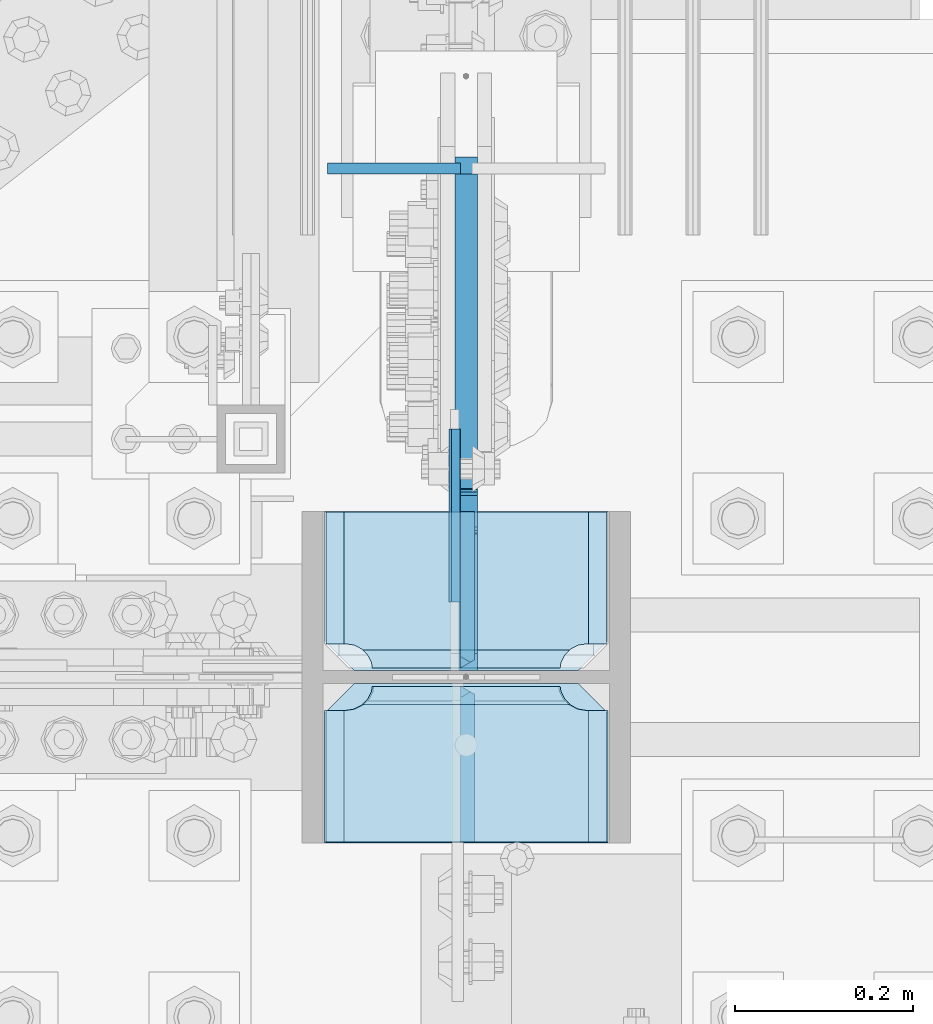
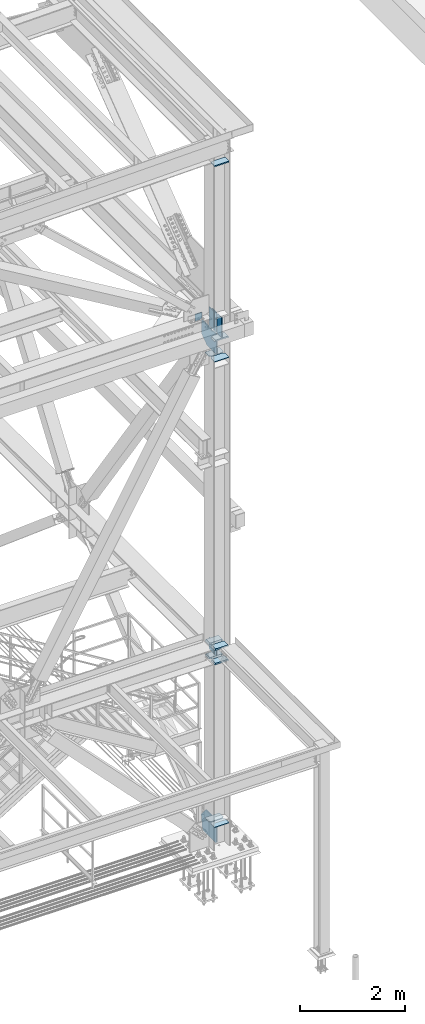
# One storey, part 3566 of 3843: 18 plates, 2 elements without a shape of their own.
"""IFC2X3 building model written with IfcOpenShell, lengths in millimetres."""

from ifc_helpers import new_model, si_unit, frame, origin_with_axes, place, context, subcontext, project, spatial, faceted_brep, material, type_object, element, aggregate, save


model = new_model("IFC2X3")

# Units and contexts
model_context = context("Model", 3, precision=1e-05, world=origin_with_axes())
body_context = subcontext(model_context, "Body", "Model", "MODEL_VIEW")
ifc_project = project(units=[si_unit("LENGTHUNIT", "METRE", prefix="MILLI"), si_unit("AREAUNIT", "SQUARE_METRE"), si_unit("VOLUMEUNIT", "CUBIC_METRE"), si_unit("MASSUNIT", "GRAM", prefix="KILO"), si_unit("TIMEUNIT", "SECOND"), si_unit("PLANEANGLEUNIT", "RADIAN"), si_unit("SOLIDANGLEUNIT", "STERADIAN"), si_unit("THERMODYNAMICTEMPERATUREUNIT", "DEGREE_CELSIUS"), si_unit("LUMINOUSINTENSITYUNIT", "LUMEN")], contexts=[model_context])

# Site, building, storey
site_placement = place(None, origin_with_axes())
site = spatial("IfcSite", under=ifc_project, at=site_placement, CompositionType="ELEMENT")
building_placement = place(site_placement, origin_with_axes())
building = spatial("IfcBuilding", under=site, at=building_placement, Name="Undefined", CompositionType="ELEMENT")
storey_placement = place(building_placement, origin_with_axes())
storey = spatial("IfcBuildingStorey", under=building, at=storey_placement, Name="Undefined", CompositionType="ELEMENT", Elevation=0.0)

# Assembly, plate
assembly_1_placement = place(storey_placement, origin_with_axes())
assembly_1 = element("IfcElementAssembly", 1, at=assembly_1_placement, inside=storey, Name="BEAM", AssemblyPlace="NOTDEFINED", PredefinedType="RIGID_FRAME")
ifc_material = material(Name="STEEL/A572-50")
plate_type_1 = type_object("IfcPlateType", PredefinedType="NOTDEFINED")
plate_1_placement = place(assembly_1_placement, frame((85493.225, 15568.6522904443, 42110.025), z_axis=(0.0, 0.0, -1.0), x_axis=(1.0, 0.0, 0.0)))
plate_1 = element("IfcPlate", 2, at=plate_1_placement, type_object=plate_type_1, material=ifc_material, Name="PLATE", context=body_context, shape_type="Brep", body=[
    faceted_brep([(0.0, -6.3499999046162, 0.0), (0.0, -6.34999999999854, 163.512499999997), (0.0, 6.34999999999854, 163.512499999997), (7.27595761418343e-12, 6.3499999046162, 0.0), (117.474999999991, -6.34999999999854, 163.512499999997), (117.474999999991, 6.34999999999854, 163.512499999997), (149.224999999991, -6.34999999999854, 131.762499999997), (149.224999999991, 6.34999999999854, 131.762499999997), (149.224999999991, -6.35000000000582, 0.0), (149.224999999991, 6.35000000000582, 0.0)], [[[0, 1, 2, 3]], [[1, 4, 5, 2]], [[4, 6, 7, 5]], [[6, 8, 9, 7]], [[8, 0, 3, 9]], [[5, 7, 9, 3, 2]], [[8, 6, 4, 1, 0]]]),
])
aggregate(assembly_1, [plate_1])

# Assembly, plates
assembly_2_placement = place(storey_placement, origin_with_axes())
assembly_2 = element("IfcElementAssembly", 3, at=assembly_2_placement, inside=storey, Name="COLUMN", AssemblyPlace="NOTDEFINED", PredefinedType="RIGID_FRAME")
plate_type_2 = type_object("IfcPlateType", PredefinedType="NOTDEFINED")
plate_2_placement = place(assembly_2_placement, frame((85807.55, 15005.84375, 41459.7674550798), z_axis=(0.0, 1.0, 0.0), x_axis=(-1.0, 0.0, 0.0)))
plate_2 = element("IfcPlate", 4, at=plate_2_placement, type_object=plate_type_2, material=ifc_material, Name="CB_COL", context=body_context, shape_type="Brep", body=[
    faceted_brep([(0.0, -6.34999999999854, 33.3375015258789), (0.0, -6.34999999999854, 178.59375), (0.0, 6.34999999999854, 178.59375), (0.0, 6.34999999999854, 33.3375015258789), (317.499999999985, -6.34999999999854, 178.59375), (317.499999999985, 6.34999999999854, 178.59375), (317.499999999985, -6.34999999999854, 33.3375015258789), (317.499999999985, 6.34999999999854, 33.3375015258789), (284.162498474107, -6.34999999999854, 0.0), (284.162498474107, 6.34999999999854, 0.0), (33.3375015258789, -6.34999999999854, 0.0), (33.3375015258789, 6.34999999999854, 0.0)], [[[0, 1, 2, 3]], [[1, 4, 5, 2]], [[4, 6, 7, 5]], [[6, 8, 9, 7]], [[8, 10, 11, 9]], [[10, 0, 3, 11]], [[5, 7, 9, 11, 3, 2]], [[10, 8, 6, 4, 1, 0]]]),
])
plate_3_placement = place(assembly_2_placement, frame((85807.55, 14991.55625, 41459.7674550798), z_axis=(0.0, -1.0, 0.0), x_axis=(-1.0, 0.0, 0.0)))
plate_3 = element("IfcPlate", 5, at=plate_3_placement, type_object=plate_type_2, material=ifc_material, Name="CB_COL", context=body_context, shape_type="Brep", body=[
    faceted_brep([(0.0, -6.34999999999854, 33.3375015258789), (0.0, -6.34999999999854, 178.59375), (0.0, 6.34999999999854, 178.59375), (0.0, 6.34999999999854, 33.3375015258789), (317.499999999985, -6.34999999999854, 178.59375), (317.499999999985, 6.34999999999854, 178.59375), (317.499999999985, -6.34999999999854, 33.3375015258789), (317.499999999985, 6.34999999999854, 33.3375015258789), (284.162498474107, -6.34999999999854, 0.0), (284.162498474107, 6.34999999999854, 0.0), (33.3375015258789, -6.34999999999854, 0.0), (33.3375015258789, 6.34999999999854, 0.0)], [[[0, 1, 2, 3]], [[1, 4, 5, 2]], [[4, 6, 7, 5]], [[6, 8, 9, 7]], [[8, 10, 11, 9]], [[10, 0, 3, 11]], [[5, 7, 9, 11, 3, 2]], [[10, 8, 6, 4, 1, 0]]]),
])
plate_4_placement = place(assembly_2_placement, frame((85807.55, 15005.84375, 30683.648293866), z_axis=(0.0, 1.0, 0.0), x_axis=(-1.0, 0.0, 0.0)))
plate_4 = element("IfcPlate", 6, at=plate_4_placement, type_object=plate_type_2, material=ifc_material, Name="CB_COL", context=body_context, shape_type="Brep", body=[
    faceted_brep([(0.0, -6.34999999999854, 33.3375015258789), (0.0, -6.34999999999854, 178.59375), (0.0, 6.34999999999854, 178.59375), (0.0, 6.34999999999854, 33.3375015258789), (317.499999999985, -6.34999999999854, 178.59375), (317.499999999985, 6.34999999999854, 178.59375), (317.499999999985, -6.34999999999854, 33.3375015258789), (317.499999999985, 6.34999999999854, 33.3375015258789), (284.162498474107, -6.34999999999854, 0.0), (284.162498474107, 6.34999999999854, 0.0), (33.3375015258789, -6.34999999999854, 0.0), (33.3375015258789, 6.34999999999854, 0.0)], [[[0, 1, 2, 3]], [[1, 4, 5, 2]], [[4, 6, 7, 5]], [[6, 8, 9, 7]], [[8, 10, 11, 9]], [[10, 0, 3, 11]], [[5, 7, 9, 11, 3, 2]], [[10, 8, 6, 4, 1, 0]]]),
])
plate_5_placement = place(assembly_2_placement, frame((85807.55, 14991.55625, 30683.648293866), z_axis=(0.0, -1.0, 0.0), x_axis=(-1.0, 0.0, 0.0)))
plate_5 = element("IfcPlate", 7, at=plate_5_placement, type_object=plate_type_2, material=ifc_material, Name="CB_COL", context=body_context, shape_type="Brep", body=[
    faceted_brep([(0.0, -6.34999999999854, 33.3375015258789), (0.0, -6.34999999999854, 178.59375), (0.0, 6.34999999999854, 178.59375), (0.0, 6.34999999999854, 33.3375015258789), (317.499999999985, -6.34999999999854, 178.59375), (317.499999999985, 6.34999999999854, 178.59375), (317.499999999985, -6.34999999999854, 33.3375015258789), (317.499999999985, 6.34999999999854, 33.3375015258789), (284.162498474107, -6.34999999999854, 0.0), (284.162498474107, 6.34999999999854, 0.0), (33.3375015258789, -6.34999999999854, 0.0), (33.3375015258789, 6.34999999999854, 0.0)], [[[0, 1, 2, 3]], [[1, 4, 5, 2]], [[4, 6, 7, 5]], [[6, 8, 9, 7]], [[8, 10, 11, 9]], [[10, 0, 3, 11]], [[5, 7, 9, 11, 3, 2]], [[10, 8, 6, 4, 1, 0]]]),
])
plate_type_3 = type_object("IfcPlateType", PredefinedType="NOTDEFINED")
plate_6_placement = place(assembly_2_placement, frame((85809.1375, 14991.55625, 41941.75), z_axis=(-1.0, 0.0, 0.0), x_axis=(0.0, -1.0, 0.0)))
plate_6 = element("IfcPlate", 8, at=plate_6_placement, type_object=plate_type_3, material=ifc_material, Name="PLATE", context=body_context, shape_type="Brep", body=[
    faceted_brep([(17.7290728964945, 9.33296078367857, 270.873024980028), (21.5061209990872, 15.875, 274.650073082623), (21.5061209990872, 15.875, 46.0249269173801), (17.7290728964945, 9.33296078367857, 49.8019750199746), (9.32072521071495, -5.23072461579432, 54.0862421540805), (3.17524995231724, -15.875, 55.0595898134052), (3.17524995231724, -15.875, 265.615410186598), (9.32072521071677, -5.23072461578704, 266.588757845922), (177.799999999999, 15.875, 21.5053709990898), (177.799999999999, -15.875, 3.17449995232164), (30.1625003814697, -15.875, 3.17449995232164), (30.1625003814697, 15.875, 21.5053709990898), (30.1625003814697, 15.875, 299.168629000924), (30.1625003814697, -15.875, 317.499500047692), (177.799999999999, -15.875, 317.499500047692), (177.799999999999, 15.875, 299.168629000924), (9.32072521071677, -15.875, 266.588757845922), (17.7290728964945, -15.875, 270.873024980028), (24.4019754014498, -15.875, 277.545927484985), (24.4019754014498, 15.875, 277.545927484985), (28.6862425355521, -15.875, 285.954275170763), (28.6862425355521, 15.875, 285.954275170763), (30.1625003814697, -15.875, 295.275000381473), (30.1625003814697, 15.875, 295.275000381473), (30.1625003814697, -15.875, 25.3999996185303), (30.1625003814697, 15.875, 25.3999996185303), (28.6862425355521, -15.875, 34.7207248292398), (28.6862425355521, 15.875, 34.7207248292398), (24.4019754014498, -15.875, 43.1290725150175), (24.4019754014498, 15.875, 43.1290725150175), (17.7290728964945, -15.875, 49.8019750199746), (9.32072521071495, -15.875, 54.0862421540805)], [[[0, 1, 2, 3, 4, 5, 6, 7]], [[8, 9, 10, 11]], [[12, 13, 14, 15]], [[16, 7, 6]], [[16, 17, 0, 7]], [[17, 18, 19, 1, 0]], [[18, 20, 21, 19]], [[20, 22, 23, 21]], [[23, 22, 13, 12]], [[9, 8, 15, 14]], [[24, 25, 11, 10]], [[24, 26, 27, 25]], [[26, 28, 29, 27]], [[29, 28, 30, 3, 2]], [[30, 31, 4, 3]], [[31, 5, 4]], [[19, 21, 23, 12, 15, 8, 11, 25, 27, 29, 2, 1]], [[31, 30, 28, 26, 24, 10, 9, 14, 13, 22, 20, 18, 17, 16, 6, 5]]]),
])
plate_type_4 = type_object("IfcPlateType", PredefinedType="NOTDEFINED")
plate_7_placement = place(assembly_2_placement, frame((85636.89375, 15276.512498474, 34761.4875), z_axis=(0.0, 0.0, -1.0), x_axis=(0.0, -1.0, 0.0)))
plate_7 = element("IfcPlate", 9, at=plate_7_placement, type_object=plate_type_4, material=ifc_material, Name="PLATE", context=body_context, shape_type="Brep", body=[
    faceted_brep([(0.0, -4.76249999999709, 0.0), (1.45519152283669e-11, -4.76249999999709, 269.874990844721), (1.45519152283669e-11, 4.76249999999709, 269.874990844721), (0.0, 4.76249999999709, 0.0), (193.675000000003, -4.76249999999709, 269.874990844721), (193.675000000003, 4.76249999999709, 269.874990844721), (193.674999999996, -4.76249999999709, 0.0), (193.674999999996, 4.76249999999709, 0.0)], [[[0, 1, 2, 3]], [[1, 4, 5, 2]], [[4, 6, 7, 5]], [[6, 0, 3, 7]], [[5, 7, 3, 2]], [[6, 4, 1, 0]]]),
])
plate_type_5 = type_object("IfcPlateType", PredefinedType="NOTDEFINED")
plate_8_placement = place(assembly_2_placement, frame((85649.59375, 15005.8442500019, 34496.375), z_axis=(0.0, 0.707106781186548, 0.707106781186548), x_axis=(5.70000238222118e-08, 0.707106781186546, -0.707106781186546)))
plate_8 = element("IfcPlate", 10, at=plate_8_placement, type_object=plate_type_5, material=ifc_material, Name="PLATE", context=body_context, shape_type="Brep", body=[
    faceted_brep([(-184.095250465922, 7.9375, 188.585378458942), (4.49012799373304, 7.9375, 0.0), (13.4703841824085, -3.06102271161217, -3.63797880709171e-12), (13.4703841830633, -7.9375, 3.98162703275011), (-180.113623446356, -7.9375, 197.565634661863), (-184.095250465834, -3.06102272757562, 197.565634661427), (-62.5551309118237, -7.93749999991269, 315.124127196395), (-69.036072523144, 7.9375, 321.605068804565), (-184.095250465754, 7.9375, 206.545890861948), (22.4506403697887, 7.9375, -1.81898940354586e-11), (137.509818323706, 7.93750000094587, 115.059177953997), (131.028876714001, -7.9375, 121.540119563797), (128.529562034935, 7.9375, 124.039434242863), (128.529562034935, -7.9375, 124.039434242863), (-60.0558162178277, 7.9375, 312.624812503636), (-60.0558162178277, -7.9375, 312.624812503636)], [[[0, 1, 2, 3, 4, 5]], [[6, 7, 8, 5, 4]], [[9, 2, 1]], [[9, 10, 11, 3, 2]], [[12, 13, 11, 10]], [[14, 15, 13, 12]], [[11, 13, 15, 6, 4, 3]], [[8, 0, 5]], [[14, 12, 10, 9, 1, 0, 8, 7]], [[15, 14, 7, 6]]]),
])
plate_9_placement = place(assembly_2_placement, frame((85650.3875, 15005.8437500036, 41976.6750000008), z_axis=(0.0, 0.707106781186548, 0.707106781186548), x_axis=(5.70000238222118e-08, 0.707106781186546, -0.707106781186546)))
plate_9 = element("IfcPlate", 11, at=plate_9_placement, type_object=plate_type_5, material=ifc_material, Name="PLATE", context=body_context, shape_type="Brep", body=[
    faceted_brep([(-312.063900187669, 7.9375, 316.55402818077), (4.49012799373304, 7.9375, 0.0), (13.4703841824085, -3.06102271161217, -3.63797880709171e-12), (13.4703841830633, -7.9375, 3.98162703275011), (-308.082273151626, -7.9375, 325.53428436687), (-312.06390018768, -3.06102270777046, 325.534284366877), (-190.523427063413, -7.9375, 443.093130455098), (-197.004368674482, 7.9375, 449.574072066178), (-312.063900187676, 7.9375, 334.514540552969), (22.4506403697887, 7.9375, -1.81898940354586e-11), (137.510171880771, 7.93750000091677, 115.059531510957), (131.029230271015, -7.9375, 121.540473120702), (62.3005266916225, 7.9375, 190.269176711488), (62.3005266916225, -7.9375, 190.269176711488), (-171.186132170253, 7.9375, 423.755835579228), (-171.186132170253, -7.9375, 423.755835579228)], [[[0, 1, 2, 3, 4, 5]], [[6, 7, 8, 5, 4]], [[9, 2, 1]], [[9, 10, 11, 3, 2]], [[12, 13, 11, 10]], [[14, 15, 13, 12]], [[11, 13, 15, 6, 4, 3]], [[8, 0, 5]], [[14, 12, 10, 9, 1, 0, 8, 7]], [[15, 14, 7, 6]]]),
])
plate_10_placement = place(assembly_2_placement, frame((85650.3875, 14991.55625, 41976.6750000001), z_axis=(0.0, -0.707106781186682, 0.707106781186413), x_axis=(0.0, -0.707106781186548, -0.707106781186548)))
plate_10 = element("IfcPlate", 12, at=plate_10_placement, type_object=plate_type_5, material=ifc_material, Name="PLATE", context=body_context, shape_type="Brep", body=[
    faceted_brep([(4.49012799309094, -7.9375, 7.27595761418343e-12), (-312.063900203553, -7.9375, 316.554028203769), (-312.063900203248, 3.06102270915289, 325.534284391004), (-308.082273168307, 7.9375, 325.534284391018), (13.470384184775, 7.9375, 3.98162703046546), (13.4703841731916, 3.06102272879798, -7.27595761418343e-12), (-312.06390018767, -7.9375, 334.514540549832), (-197.565634686391, -7.9375, 449.0128060934), (-191.084693076795, 7.93749999991269, 442.531864483506), (22.4506403026729, -7.93750001103617, 0.0), (130.467964270647, 7.9375, 120.979207121221), (136.948905880243, -7.93750000094587, 114.498265511327)], [[[0, 1, 2, 3, 4, 5]], [[6, 7, 8, 3, 2]], [[9, 0, 5]], [[10, 11, 9, 5, 4]], [[11, 10, 8, 7]], [[1, 0, 9, 11, 7, 6]], [[6, 2, 1]], [[8, 10, 4, 3]]]),
])
plate_type_6 = type_object("IfcPlateType", PredefinedType="NOTDEFINED")
plate_11_placement = place(assembly_2_placement, frame((85636.0999999999, 15276.5124995919, 42413.2375), z_axis=(0.0, 0.0, -1.0), x_axis=(0.0, -1.0, 0.0)))
plate_11 = element("IfcPlate", 13, at=plate_11_placement, type_object=plate_type_6, material=ifc_material, Name="PLATE", context=body_context, shape_type="Brep", body=[
    faceted_brep([(0.0, -6.3499999046162, 0.0), (0.0, -6.35000000000582, 431.800000000003), (0.0, 6.35000000000582, 431.800000000003), (7.27595761418343e-12, 6.3499999046162, 0.0), (193.674999999996, -6.35000000000582, 431.800000000003), (193.674999999996, 6.35000000000582, 431.800000000003), (193.674999999996, -6.35000000000582, 0.0), (193.674999999996, 6.35000000000582, 0.0)], [[[0, 1, 2, 3]], [[1, 4, 5, 2]], [[4, 6, 7, 5]], [[6, 0, 3, 7]], [[5, 7, 3, 2]], [[6, 4, 1, 0]]]),
])
plate_type_7 = type_object("IfcPlateType", PredefinedType="NOTDEFINED")
plate_12_placement = place(assembly_2_placement, frame((85807.55, 14991.55625, 45988.2875), z_axis=(-1.0, 0.0, 0.0), x_axis=(0.0, -1.0, 0.0)))
plate_12 = element("IfcPlate", 14, at=plate_12_placement, type_object=plate_type_7, material=ifc_material, Name="PLATE", context=body_context, shape_type="Brep", body=[
    faceted_brep([(17.7290728964945, 10.9204600207377, 267.698024980025), (19.6730343348936, 14.2874999999985, 269.641986418414), (19.6730343348972, 14.2874999999985, 47.8580135815719), (17.7290728964945, 10.9204600207304, 49.8019750199746), (9.32072521071677, -3.6432253787425, 54.0862421540805), (3.17524995232088, -14.2874999999985, 55.0595898134052), (3.17524995231361, -14.2874999999985, 262.440410186595), (9.32072521071495, -3.64322537872067, 263.413757845919), (9.32072521071677, -14.2874999999985, 263.413757845919), (17.7290728964945, -14.2874999999985, 267.698024980025), (24.4019754014516, -14.2874999999985, 274.370927484983), (24.4019754014516, 14.2874999999985, 274.370927484983), (28.6862425355539, -14.2874999999985, 282.77927517076), (28.6862425355539, 14.2874999999985, 282.77927517076), (30.1625003814697, -14.2874999999985, 292.10000038147), (30.1625003814697, 14.2874999999985, 292.10000038147), (30.1625003814697, -14.2874999999985, 317.5), (30.1625003814697, 14.2874999999985, 317.5), (177.800003051758, -14.2874999999985, 317.5), (177.800003051758, 14.2874999999985, 317.5), (177.800003051758, -14.2874999999985, 0.0), (177.800003051758, 14.2874999999985, 0.0), (30.1625003814697, -14.2874999999985, 0.0), (30.1625003814697, 14.2874999999985, 0.0), (30.1625003814697, -14.2874999999985, 25.3999996185303), (30.1625003814697, 14.2874999999985, 25.3999996185303), (28.6862425355503, -14.2874999999985, 34.7207248292398), (28.6862425355503, 14.2874999999985, 34.7207248292398), (24.401975401448, -14.2874999999985, 43.1290725150175), (24.401975401448, 14.2874999999985, 43.1290725150175), (17.7290728964945, -14.2874999999985, 49.8019750199746), (9.32072521071677, -14.2874999999985, 54.0862421540805)], [[[0, 1, 2, 3, 4, 5, 6, 7]], [[8, 7, 6]], [[8, 9, 0, 7]], [[9, 10, 11, 1, 0]], [[10, 12, 13, 11]], [[12, 14, 15, 13]], [[14, 16, 17, 15]], [[16, 18, 19, 17]], [[18, 20, 21, 19]], [[20, 22, 23, 21]], [[22, 24, 25, 23]], [[24, 26, 27, 25]], [[26, 28, 29, 27]], [[29, 28, 30, 3, 2]], [[30, 31, 4, 3]], [[31, 5, 4]], [[11, 13, 15, 17, 19, 21, 23, 25, 27, 29, 2, 1]], [[31, 30, 28, 26, 24, 22, 20, 18, 16, 14, 12, 10, 9, 8, 6, 5]]]),
])
plate_type_8 = type_object("IfcPlateType", PredefinedType="NOTDEFINED")
plate_13_placement = place(assembly_2_placement, frame((85809.1375, 14991.55625, 34459.8625), z_axis=(-1.0, 0.0, 0.0), x_axis=(0.0, -1.0, 0.0)))
plate_13 = element("IfcPlate", 15, at=plate_13_placement, type_object=plate_type_8, material=ifc_material, Name="PLATE", context=body_context, shape_type="Brep", body=[
    faceted_brep([(17.7290728964945, 7.7454615466122, 270.873024980028), (23.3392076632808, 17.4625000000015, 276.483159746815), (23.3392076632808, 17.4625000000015, 44.1918402531883), (17.7290728964945, 7.7454615466122, 49.8019750199746), (9.32072521071495, -6.81822385286068, 54.0862421540805), (3.17524995231724, -17.4625000000015, 55.0595898134052), (3.17524995231724, -17.4625000000015, 265.615410186598), (9.32072521071677, -6.81822385286068, 266.588757845922), (177.800000000001, 17.4625000000015, 23.338457663267), (177.800000000001, -17.4625000000015, 3.17449995230709), (30.1625003814697, -17.4625000000015, 3.17449995230709), (30.1625003814697, 17.4625000000015, 23.338457663267), (30.1625003814697, 17.4625000000015, 297.335542336717), (30.1625003814697, -17.4625000000015, 317.499500047677), (177.800000000001, -17.4625000000015, 317.499500047677), (177.800000000001, 17.4625000000015, 297.335542336717), (9.32072521071677, -17.4625000000015, 266.588757845922), (17.7290728964945, -17.4625000000015, 270.873024980028), (24.4019754014498, -17.4625000000015, 277.545927484985), (24.4019754014498, 17.4625000000015, 277.545927484985), (28.6862425355521, -17.4625000000015, 285.954275170763), (28.6862425355521, 17.4625000000015, 285.954275170763), (30.1625003814697, -17.4625000000015, 295.275000381473), (30.1625003814697, 17.4625000000015, 295.275000381473), (30.1625003814697, -17.4625000000015, 25.3999996185303), (30.1625003814697, 17.4625000000015, 25.3999996185303), (28.6862425355521, -17.4625000000015, 34.7207248292398), (28.6862425355521, 17.4625000000015, 34.7207248292398), (24.4019754014498, -17.4625000000015, 43.1290725150175), (24.4019754014498, 17.4625000000015, 43.1290725150175), (17.7290728964945, -17.4625000000015, 49.8019750199746), (9.32072521071495, -17.4625000000015, 54.0862421540805)], [[[0, 1, 2, 3, 4, 5, 6, 7]], [[8, 9, 10, 11]], [[12, 13, 14, 15]], [[16, 7, 6]], [[16, 17, 0, 7]], [[17, 18, 19, 1, 0]], [[18, 20, 21, 19]], [[20, 22, 23, 21]], [[23, 22, 13, 12]], [[15, 14, 9, 8]], [[24, 25, 11, 10]], [[24, 26, 27, 25]], [[26, 28, 29, 27]], [[29, 28, 30, 3, 2]], [[30, 31, 4, 3]], [[31, 5, 4]], [[19, 21, 23, 12, 15, 8, 11, 25, 27, 29, 2, 1]], [[31, 30, 28, 26, 24, 10, 9, 14, 13, 22, 20, 18, 17, 16, 6, 5]]]),
])
plate_14_placement = place(assembly_2_placement, frame((85809.1375, 14991.55625, 34793.2375), z_axis=(-1.0, 0.0, 0.0), x_axis=(0.0, -1.0, 0.0)))
plate_14 = element("IfcPlate", 16, at=plate_14_placement, type_object=plate_type_8, material=ifc_material, Name="PLATE", context=body_context, shape_type="Brep", body=[
    faceted_brep([(17.7290728964945, 7.7454615466122, 270.873024980028), (23.3392076632808, 17.4625000000015, 276.483159746815), (23.3392076632808, 17.4625000000015, 44.1918402531883), (17.7290728964945, 7.7454615466122, 49.8019750199746), (9.32072521071495, -6.81822385286068, 54.0862421540805), (3.17524995231724, -17.4625000000015, 55.0595898134052), (3.17524995231724, -17.4625000000015, 265.615410186598), (9.32072521071677, -6.81822385286068, 266.588757845922), (177.800000000001, 17.4625000000015, 23.338457663267), (177.800000000001, -17.4625000000015, 3.17449995230709), (30.1625003814697, -17.4625000000015, 3.17449995230709), (30.1625003814697, 17.4625000000015, 23.338457663267), (30.1625003814697, 17.4625000000015, 297.335542336717), (30.1625003814697, -17.4625000000015, 317.499500047677), (177.800000000001, -17.4625000000015, 317.499500047677), (177.800000000001, 17.4625000000015, 297.335542336717), (9.32072521071677, -17.4625000000015, 266.588757845922), (17.7290728964945, -17.4625000000015, 270.873024980028), (24.4019754014498, -17.4625000000015, 277.545927484985), (24.4019754014498, 17.4625000000015, 277.545927484985), (28.6862425355521, -17.4625000000015, 285.954275170763), (28.6862425355521, 17.4625000000015, 285.954275170763), (30.1625003814697, -17.4625000000015, 295.275000381473), (30.1625003814697, 17.4625000000015, 295.275000381473), (30.1625003814697, -17.4625000000015, 25.3999996185303), (30.1625003814697, 17.4625000000015, 25.3999996185303), (28.6862425355521, -17.4625000000015, 34.7207248292398), (28.6862425355521, 17.4625000000015, 34.7207248292398), (24.4019754014498, -17.4625000000015, 43.1290725150175), (24.4019754014498, 17.4625000000015, 43.1290725150175), (17.7290728964945, -17.4625000000015, 49.8019750199746), (9.32072521071495, -17.4625000000015, 54.0862421540805)], [[[0, 1, 2, 3, 4, 5, 6, 7]], [[8, 9, 10, 11]], [[12, 13, 14, 15]], [[16, 7, 6]], [[16, 17, 0, 7]], [[17, 18, 19, 1, 0]], [[18, 20, 21, 19]], [[20, 22, 23, 21]], [[23, 22, 13, 12]], [[15, 14, 9, 8]], [[24, 25, 11, 10]], [[24, 26, 27, 25]], [[26, 28, 29, 27]], [[29, 28, 30, 3, 2]], [[30, 31, 4, 3]], [[31, 5, 4]], [[19, 21, 23, 12, 15, 8, 11, 25, 27, 29, 2, 1]], [[31, 30, 28, 26, 24, 10, 9, 14, 13, 22, 20, 18, 17, 16, 6, 5]]]),
])
plate_15_placement = place(assembly_2_placement, frame((85809.1375, 15183.64375, 34459.8625), z_axis=(-1.0, 0.0, 0.0), x_axis=(0.0, -1.0, 0.0)))
plate_15 = element("IfcPlate", 17, at=plate_15_placement, type_object=plate_type_8, material=ifc_material, Name="PLATE", context=body_context, shape_type="Brep", body=[
    faceted_brep([(160.070927103507, 7.74546154661948, 49.8019750199746), (154.460792336722, 17.4625000000015, 44.1918402531883), (154.460792336722, 17.4625000000015, 276.483159746815), (160.070927103507, 7.74546154661948, 270.873024980028), (168.479274789286, -6.81822385286068, 266.588757845922), (174.624750047686, -17.4625000000015, 265.615410186598), (174.624750047686, -17.4625000000015, 55.0595898134052), (168.479274789286, -6.81822385286068, 54.0862421540805), (147.637502670288, 17.4625000000015, 23.3384576632816), (147.637502670288, -17.4625000000015, 3.17449995232164), (0.0, -17.4625000000015, 3.17449995232164), (0.0, 17.4625000000015, 23.3384576632816), (0.0, 17.4625000000015, 297.335542336732), (0.0, -17.4625000000015, 317.499500047692), (147.637502670288, -17.4625000000015, 317.499500047692), (147.637502670288, 17.4625000000015, 297.335542336732), (147.637502670288, -17.4625000000015, 295.274988174438), (147.637502670288, 17.4625000000015, 295.274988174438), (149.113760516208, -17.4625000000015, 285.954262963729), (149.113760516208, 17.4625000000015, 285.954262963729), (153.398027650313, -17.4625000000015, 277.545915277951), (153.398027650313, 17.4625000000015, 277.545915277951), (160.070930155271, -17.4625000000015, 270.873012772994), (168.479277841048, -17.4625000000015, 266.588745638888), (168.479277841048, -17.4625000000015, 54.0862421540805), (160.070930155271, -17.4625000000015, 49.8019750199746), (153.398027650313, -17.4625000000015, 43.1290725150175), (153.398027650313, 17.4625000000015, 43.1290725150175), (149.113760516208, -17.4625000000015, 34.7207248292398), (149.113760516208, 17.4625000000015, 34.7207248292398), (147.637502670288, -17.4625000000015, 25.3999996185303), (147.637502670288, 17.4625000000015, 25.3999996185303)], [[[0, 1, 2, 3, 4, 5, 6, 7]], [[8, 9, 10, 11]], [[12, 13, 14, 15]], [[13, 12, 11, 10]], [[16, 17, 15, 14]], [[16, 18, 19, 17]], [[18, 20, 21, 19]], [[21, 20, 22, 3, 2]], [[22, 23, 4, 3]], [[23, 5, 4]], [[24, 7, 6]], [[24, 25, 0, 7]], [[25, 26, 27, 1, 0]], [[26, 28, 29, 27]], [[28, 30, 31, 29]], [[31, 30, 9, 8]], [[27, 29, 31, 8, 11, 12, 15, 17, 19, 21, 2, 1]], [[9, 30, 28, 26, 25, 24, 6, 5, 23, 22, 20, 18, 16, 14, 13, 10]]]),
])
plate_16_placement = place(assembly_2_placement, frame((85809.1375, 15183.64375, 34793.2375), z_axis=(-1.0, 0.0, 0.0), x_axis=(0.0, -1.0, 0.0)))
plate_16 = element("IfcPlate", 18, at=plate_16_placement, type_object=plate_type_8, material=ifc_material, Name="PLATE", context=body_context, shape_type="Brep", body=[
    faceted_brep([(160.070927103507, 7.74546154661948, 49.8019750199746), (154.460792336722, 17.4625000000015, 44.1918402531883), (154.460792336722, 17.4625000000015, 276.483159746815), (160.070927103507, 7.74546154661948, 270.873024980028), (168.479274789286, -6.81822385286068, 266.588757845922), (174.624750047686, -17.4625000000015, 265.615410186598), (174.624750047686, -17.4625000000015, 55.0595898134052), (168.479274789286, -6.81822385286068, 54.0862421540805), (147.637502670288, 17.4625000000015, 23.3384576632816), (147.637502670288, -17.4625000000015, 3.17449995232164), (0.0, -17.4625000000015, 3.17449995232164), (0.0, 17.4625000000015, 23.3384576632816), (0.0, 17.4625000000015, 297.335542336732), (0.0, -17.4625000000015, 317.499500047692), (147.637502670288, -17.4625000000015, 317.499500047692), (147.637502670288, 17.4625000000015, 297.335542336732), (147.637502670288, -17.4625000000015, 295.274988174438), (147.637502670288, 17.4625000000015, 295.274988174438), (149.113760516208, -17.4625000000015, 285.954262963729), (149.113760516208, 17.4625000000015, 285.954262963729), (153.398027650313, -17.4625000000015, 277.545915277951), (153.398027650313, 17.4625000000015, 277.545915277951), (160.070930155271, -17.4625000000015, 270.873012772994), (168.479277841048, -17.4625000000015, 266.588745638888), (168.479277841048, -17.4625000000015, 54.0862421540805), (160.070930155271, -17.4625000000015, 49.8019750199746), (153.398027650313, -17.4625000000015, 43.1290725150175), (153.398027650313, 17.4625000000015, 43.1290725150175), (149.113760516208, -17.4625000000015, 34.7207248292398), (149.113760516208, 17.4625000000015, 34.7207248292398), (147.637502670288, -17.4625000000015, 25.3999996185303), (147.637502670288, 17.4625000000015, 25.3999996185303)], [[[0, 1, 2, 3, 4, 5, 6, 7]], [[8, 9, 10, 11]], [[12, 13, 14, 15]], [[13, 12, 11, 10]], [[16, 17, 15, 14]], [[16, 18, 19, 17]], [[18, 20, 21, 19]], [[21, 20, 22, 3, 2]], [[22, 23, 4, 3]], [[23, 5, 4]], [[24, 7, 6]], [[24, 25, 0, 7]], [[25, 26, 27, 1, 0]], [[26, 28, 29, 27]], [[28, 30, 31, 29]], [[31, 30, 9, 8]], [[27, 29, 31, 8, 11, 12, 15, 17, 19, 21, 2, 1]], [[9, 30, 28, 26, 25, 24, 6, 5, 23, 22, 20, 18, 16, 14, 13, 10]]]),
])
plate_type_9 = type_object("IfcPlateType", PredefinedType="NOTDEFINED")
plate_17_placement = place(assembly_2_placement, frame((85648.8, 15005.84375, 30149.8), z_axis=(0.0, 0.0, 1.0), x_axis=(0.0, 1.0, 0.0)))
plate_17 = element("IfcPlate", 19, at=plate_17_placement, type_object=plate_type_9, material=ifc_material, Name="CB", context=body_context, shape_type="Brep", body=[
    faceted_brep([(0.0, -12.6999999999971, 19.0499992370605), (0.0, -12.6999999999971, 508.448294628935), (0.0, 12.6999999999971, 508.448294628935), (0.0, 12.6999999999971, 19.0499992370605), (19.0499992370605, -12.6999999999971, 527.498293865996), (19.0499992370605, 12.6999999999971, 527.498293865996), (411.893151310356, -12.6999999999971, 527.498293865996), (411.893151310356, 12.6999999999971, 527.498293865996), (575.484929602242, -12.6999999999971, 333.509226566446), (575.484929602242, 12.6999999999971, 333.509226566446), (527.049999999999, -12.6999999999971, 0.0), (527.049999999999, 12.6999999999971, 0.0), (19.0500015258731, -12.6999999999971, -6.33008312433958e-10), (19.0500015258731, 12.6999999999971, 0.0)], [[[0, 1, 2, 3]], [[1, 4, 5, 2]], [[4, 6, 7, 5]], [[6, 8, 9, 7]], [[8, 10, 11, 9]], [[10, 12, 13, 11]], [[12, 0, 3, 13]], [[5, 7, 9, 11, 13, 3, 2]], [[12, 10, 8, 6, 4, 1, 0]]]),
])
plate_type_10 = type_object("IfcPlateType", PredefinedType="NOTDEFINED")
plate_18_placement = place(assembly_2_placement, frame((85648.8, 15562.3022904443, 41925.875), z_axis=(0.0, 0.0, -1.0), x_axis=(0.0, -1.0, 0.0)))
plate_18 = element("IfcPlate", 20, at=plate_18_placement, type_object=plate_type_10, material=ifc_material, Name="CB", context=body_context, shape_type="Brep", body=[
    faceted_brep([(352.464790444301, -12.6999999999971, 0.0), (352.464790444301, 12.6999999999971, 0.0), (352.464790444301, 12.6999999999971, 12.699999427794), (352.464790444301, -12.6999999999971, 12.699999427794), (353.431520366888, 12.6999999999971, 17.5600789458404), (353.431520366888, -12.6999999999971, 17.5600789458404), (356.184534267366, 12.6999999999971, 21.680255413994), (356.184534267366, -12.6999999999971, 21.680255413994), (360.30471073552, 12.6999999999971, 24.4332693144679), (360.30471073552, -12.6999999999971, 24.4332693144679), (365.164790253566, 12.6999999999971, 25.3999992370591), (365.164790253566, -12.6999999999971, 25.3999992370591), (390.564789872096, 12.6999999999971, 25.3999992370591), (390.564789872096, -12.6999999999971, 25.3999992370591), (395.424869390143, 12.6999999999971, 24.4332693144679), (395.424869390143, -12.6999999999971, 24.4332693144679), (399.545045858296, 12.6999999999971, 21.680255413994), (399.545045858296, -12.6999999999971, 21.680255413994), (402.298059758774, 12.6999999999971, 17.5600789458404), (402.298059758774, -12.6999999999971, 17.5600789458404), (403.264789681361, -12.6999999999971, 12.699999427794), (403.264789681361, 12.6999999999971, 12.699999427794), (403.264789681361, 12.6999999999971, 0.0), (403.264789681361, -12.6999999999971, 0.0), (0.0, -12.6999999999971, 0.0), (0.0, -12.6999999999971, 319.400114350799), (0.0, 12.6999999999971, 319.400114350799), (0.0, 12.6999999999971, 0.0), (200.169471470981, -12.6999999999971, 459.757544920147), (200.169471470981, 12.6999999999971, 459.757544920147), (537.408541207245, -12.6999999999971, 459.757544920147), (537.408541207245, 12.6999999999971, 459.757544920147), (556.458540444306, -12.6999999999971, 440.707545683086), (556.458540444306, 12.6999999999971, 440.707545683086), (556.458540444306, -12.6999999999971, 19.0499992370605), (556.458540444306, 12.6999999999971, 19.0499992370605), (537.408541207245, -12.6999999999971, 0.0), (537.408541207245, 12.6999999999971, 0.0)], [[[0, 1, 2, 3]], [[3, 2, 4, 5]], [[5, 4, 6, 7]], [[7, 6, 8, 9]], [[9, 8, 10, 11]], [[11, 10, 12, 13]], [[13, 12, 14, 15]], [[15, 14, 16, 17]], [[17, 16, 18, 19]], [[20, 21, 22, 23]], [[19, 18, 21, 20]], [[24, 25, 26, 27]], [[25, 28, 29, 26]], [[28, 30, 31, 29]], [[30, 32, 33, 31]], [[32, 34, 35, 33]], [[34, 36, 37, 35]], [[37, 36, 23, 22]], [[16, 14, 12, 10, 8, 6, 4, 2, 1, 27, 26, 29, 31, 33, 35, 37, 22, 21, 18]], [[24, 27, 1, 0]], [[36, 34, 32, 30, 28, 25, 24, 0, 3, 5, 7, 9, 11, 13, 15, 17, 19, 20, 23]]]),
])
aggregate(assembly_2, [plate_7, plate_8, plate_11, plate_9, plate_6, plate_10, plate_12, plate_13, plate_14, plate_15, plate_16, plate_2, plate_3, plate_18, plate_4, plate_5, plate_17])

save(model, "model.ifc")
